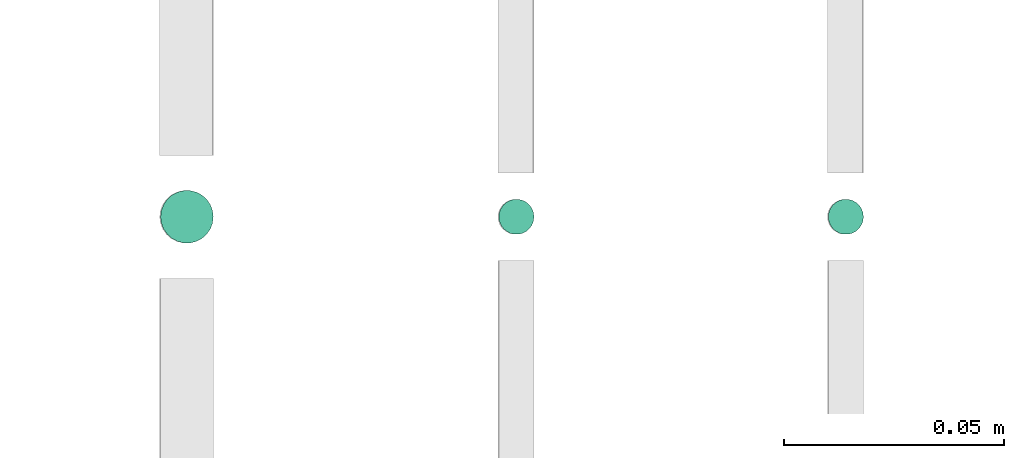
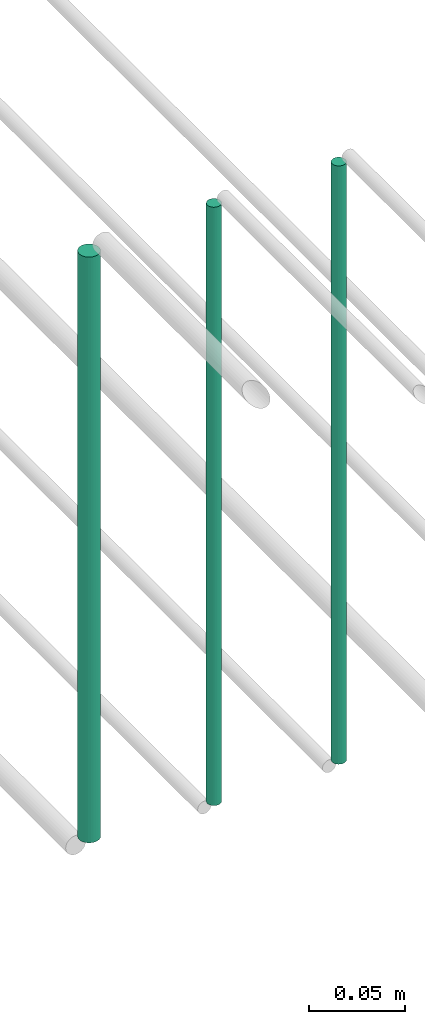
# One storey, part 147 of 331: 3 flow segments.
"""IFC2X3 building model written with IfcOpenShell, lengths in millimetres."""

from ifc_helpers import new_model, entity, si_unit, converted_unit, derived_unit, direction, frame, frame_2d, origin, origin_2d_with_axis, place, context, subcontext, project, spatial, circle, extrude, type_object, element, save


model = new_model("IFC2X3")

# Units and contexts
model_context = context("Model", 3, precision=0.01, world=origin(), true_north=direction((6.12303176911189e-17, 1.0)))
body_context = subcontext(model_context, "Body", "Model", "MODEL_VIEW")
ifc_project = project(units=[si_unit("LENGTHUNIT", "METRE", prefix="MILLI"), si_unit("AREAUNIT", "SQUARE_METRE"), si_unit("VOLUMEUNIT", "CUBIC_METRE"), converted_unit("PLANEANGLEUNIT", "DEGREE", entity("IfcRatioMeasure", 0.0174532925199433), si_unit("PLANEANGLEUNIT", "RADIAN"), dimensions=[0, 0, 0, 0, 0, 0, 0]), si_unit("MASSUNIT", "GRAM", prefix="KILO"), derived_unit("MASSDENSITYUNIT", [(si_unit("MASSUNIT", "GRAM", prefix="KILO"), 1), (si_unit("LENGTHUNIT", "METRE"), -3)]), derived_unit("MOMENTOFINERTIAUNIT", [(si_unit("LENGTHUNIT", "METRE"), 4)]), si_unit("TIMEUNIT", "SECOND"), si_unit("FREQUENCYUNIT", "HERTZ"), si_unit("THERMODYNAMICTEMPERATUREUNIT", "DEGREE_CELSIUS"), derived_unit("THERMALTRANSMITTANCEUNIT", [(si_unit("MASSUNIT", "GRAM", prefix="KILO"), 1), (si_unit("THERMODYNAMICTEMPERATUREUNIT", "KELVIN"), -1), (si_unit("TIMEUNIT", "SECOND"), -3)]), derived_unit("VOLUMETRICFLOWRATEUNIT", [(si_unit("LENGTHUNIT", "METRE"), 3), (si_unit("TIMEUNIT", "SECOND"), -1)]), derived_unit("MASSFLOWRATEUNIT", [(si_unit("MASSUNIT", "GRAM", prefix="KILO"), 1), (si_unit("TIMEUNIT", "SECOND"), -1)]), derived_unit("ROTATIONALFREQUENCYUNIT", [(si_unit("TIMEUNIT", "SECOND"), -1)]), si_unit("ELECTRICCURRENTUNIT", "AMPERE"), si_unit("ELECTRICVOLTAGEUNIT", "VOLT"), si_unit("POWERUNIT", "WATT"), si_unit("FORCEUNIT", "NEWTON", prefix="KILO"), si_unit("ILLUMINANCEUNIT", "LUX"), si_unit("LUMINOUSFLUXUNIT", "LUMEN"), si_unit("LUMINOUSINTENSITYUNIT", "CANDELA"), derived_unit("USERDEFINED", [(si_unit("MASSUNIT", "GRAM", prefix="KILO"), -1), (si_unit("LENGTHUNIT", "METRE"), -2), (si_unit("TIMEUNIT", "SECOND"), 3), (si_unit("LUMINOUSFLUXUNIT", "LUMEN"), 1)]), derived_unit("LINEARVELOCITYUNIT", [(si_unit("LENGTHUNIT", "METRE"), 1), (si_unit("TIMEUNIT", "SECOND"), -1)]), si_unit("PRESSUREUNIT", "PASCAL"), derived_unit("USERDEFINED", [(si_unit("LENGTHUNIT", "METRE"), -2), (si_unit("MASSUNIT", "GRAM", prefix="KILO"), 1), (si_unit("TIMEUNIT", "SECOND"), -2)]), derived_unit("LINEARFORCEUNIT", [(si_unit("MASSUNIT", "GRAM", prefix="KILO"), 1), (si_unit("LENGTHUNIT", "METRE"), 1), (si_unit("TIMEUNIT", "SECOND"), -2), (si_unit("LENGTHUNIT", "METRE"), -1)]), derived_unit("PLANARFORCEUNIT", [(si_unit("MASSUNIT", "GRAM", prefix="KILO"), 1), (si_unit("LENGTHUNIT", "METRE"), 1), (si_unit("TIMEUNIT", "SECOND"), -2), (si_unit("LENGTHUNIT", "METRE"), -2)])], contexts=[model_context])

# Site, building, storey
site_placement = place(None, frame((0.0, -0.00077364408347762, 0.0)))
site = spatial("IfcSite", under=ifc_project, at=site_placement, CompositionType="ELEMENT")
building_placement = place(site_placement, origin())
building = spatial("IfcBuilding", under=site, at=building_placement, CompositionType="ELEMENT")
storey_placement = place(building_placement, origin())
storey = spatial("IfcBuildingStorey", under=building, at=storey_placement, CompositionType="ELEMENT", Elevation=0.0)

# Flow segments
pipe_segment_type = type_object("IfcPipeSegmentType", PredefinedType="NOTDEFINED")
flow_segment_1_placement = place(storey_placement, frame((35540.7427281404, 5638.02529159143, 18660.0)))
element("IfcFlowSegment", 1, at=flow_segment_1_placement, inside=storey, type_object=pipe_segment_type, context=body_context, shape_type="SweptSolid", body=[
    extrude(circle(Radius=4.0, at=frame_2d((0.0, -1.08286712929839e-12), x_axis=(1.0, 0.0))), frame((5.59527223591499, 5.59527223591499, 0.0), z_axis=(0.0, 0.0, 1.0), x_axis=(-1.0, 0.0, 0.0)), (0.0, 0.0, 1.0), 379.99999999995),
])
flow_segment_2_placement = place(storey_placement, frame((35465.7427281405, 5638.02529159143, 18660.0)))
element("IfcFlowSegment", 2, at=flow_segment_2_placement, inside=storey, type_object=pipe_segment_type, context=body_context, shape_type="SweptSolid", body=[
    extrude(circle(Radius=4.0, at=origin_2d_with_axis()), frame((5.59527223591499, 5.59527223591607, 0.0), z_axis=(0.0, 0.0, 1.0), x_axis=(-1.0, 0.0, 0.0)), (0.0, 0.0, 1.0), 379.999999999989),
])
flow_segment_3_placement = place(storey_placement, frame((35388.7427281405, 5636.02529159144, 18664.0)))
element("IfcFlowSegment", 3, at=flow_segment_3_placement, inside=storey, type_object=pipe_segment_type, context=body_context, shape_type="SweptSolid", body=[
    extrude(circle(Radius=6.0, at=origin_2d_with_axis()), frame((7.59527223591454, 7.59527223591562, 0.0), z_axis=(0.0, 0.0, 1.0), x_axis=(-1.0, 0.0, 0.0)), (0.0, 0.0, 1.0), 371.999999999989),
])

save(model, "model.ifc")
